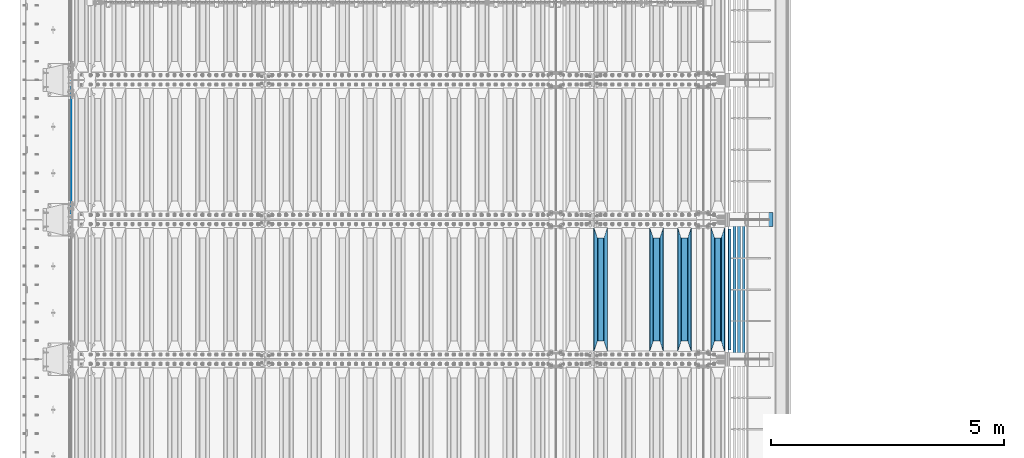
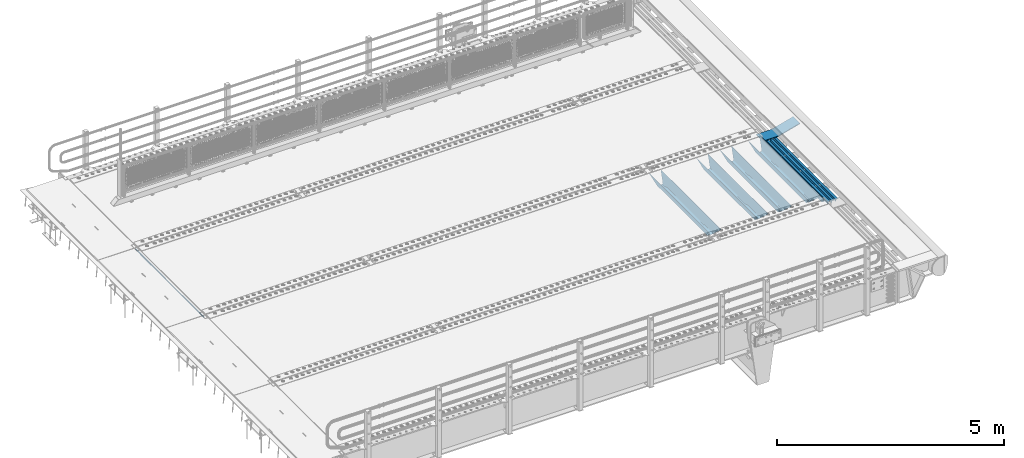
# One storey, part 111 of 240: 10 beams.
"""IFC2X3 building model written with IfcOpenShell, lengths in millimetres."""

from ifc_helpers import new_model, si_unit, frame, origin_with_axes, place, context, subcontext, project, spatial, faceted_brep, material, type_object, element, save


model = new_model("IFC2X3")

# Units and contexts
model_context = context("Model", 3, precision=1e-05, world=origin_with_axes())
body_context = subcontext(model_context, "Body", "Model", "MODEL_VIEW")
ifc_project = project(units=[si_unit("LENGTHUNIT", "METRE", prefix="MILLI"), si_unit("AREAUNIT", "SQUARE_METRE"), si_unit("VOLUMEUNIT", "CUBIC_METRE"), si_unit("MASSUNIT", "GRAM", prefix="KILO"), si_unit("TIMEUNIT", "SECOND"), si_unit("PLANEANGLEUNIT", "RADIAN"), si_unit("SOLIDANGLEUNIT", "STERADIAN"), si_unit("THERMODYNAMICTEMPERATUREUNIT", "DEGREE_CELSIUS"), si_unit("LUMINOUSINTENSITYUNIT", "LUMEN")], contexts=[model_context])

# Site, building, storey
site_placement = place(None, origin_with_axes())
site = spatial("IfcSite", under=ifc_project, at=site_placement, CompositionType="ELEMENT")
building_placement = place(site_placement, origin_with_axes())
building = spatial("IfcBuilding", under=site, at=building_placement, Name="Standard", CompositionType="ELEMENT")
storey_placement = place(building_placement, origin_with_axes())
storey = spatial("IfcBuildingStorey", under=building, at=storey_placement, Name="Undefined", CompositionType="ELEMENT", Elevation=0.0)

# Beams
ifc_material_1 = material(Name="STEEL/S355N")
beam_type_1 = type_object("IfcBeamType", Name="D20", PredefinedType="NOTDEFINED")
beam_1_placement = place(storey_placement, frame((42415.0, 30004.9999999999, -25.999999994595), z_axis=(0.0, 0.0, 1.0), x_axis=(0.0, 1.0, 0.0)))
element("IfcBeam", 1, at=beam_1_placement, inside=storey, type_object=beam_type_1, material=ifc_material_1, ObjectType="D20", context=body_context, shape_type="Brep", body=[
    faceted_brep([(0.0, -10.0, 0.0), (0.0, -7.07106781186303, -7.07106781186548), (2990.0, -7.07106781186303, -7.07106781186548), (2990.0, -10.0, 0.0), (0.0, 0.0, -10.0), (2990.0, 0.0, -10.0), (0.0, 7.07106781186303, -7.07106781186547), (2990.0, 7.07106781186303, -7.07106781186547), (0.0, 10.0, 0.0), (2990.0, 10.0, 0.0), (0.0, 7.07106781186303, 7.07106781186548), (2990.0, 7.07106781186303, 7.07106781186548), (0.0, 0.0, 10.0), (2990.0, 0.0, 10.0), (0.0, -7.07106781186303, 7.07106781186548), (2990.0, -7.07106781186303, 7.07106781186548)], [[[0, 1, 2, 3]], [[1, 4, 5, 2]], [[4, 6, 7, 5]], [[6, 8, 9, 7]], [[8, 10, 11, 9]], [[10, 12, 13, 11]], [[12, 14, 15, 13]], [[14, 0, 3, 15]], [[5, 7, 9, 11, 13, 15, 3, 2]], [[14, 12, 10, 8, 6, 4, 1, 0]]]),
])
beam_type_2 = type_object("IfcBeamType", PredefinedType="NOTDEFINED")
beam_2_placement = place(storey_placement, frame((56317.0, 27175.0, -115.0), z_axis=(0.0, 0.0, 1.0), x_axis=(0.0, 1.0, 0.0)))
element("IfcBeam", 2, at=beam_2_placement, inside=storey, type_object=beam_type_2, material=ifc_material_1, context=body_context, shape_type="Brep", body=[
    faceted_brep([(0.0, 150.0, 115.0), (0.0, 143.690000000002, 115.0), (2650.00000000297, 143.690000000002, 115.0), (2650.00000000297, 150.0, 115.0), (2650.00000000297, 142.059565218406, 110.000000003094), (2650.00000000297, 148.369565218403, 110.000000003094), (2441.90079219209, -80.1103600731149, -98.0992078077845), (2437.7588105432, -77.5672621345584, -102.241189456673), (2434.06523489747, -74.4080125315522, -105.934765102404), (2430.9108609509, -70.7102721255724, -109.089139048974), (2428.37322971128, -66.5649389910031, -111.626770288588), (2426.51472138055, -62.0739139532889, -113.485278619323), (2425.38102192092, -57.3475956567636, -114.618978078955), (2424.99999999987, -52.5021667386536, -115.0), (2424.99999999987, 52.5021667386536, -115.0), (2425.38102192092, 57.3475956567636, -114.618978078955), (2426.51472138055, 62.0739139532889, -113.485278619323), (2428.37322971128, 66.5649389910031, -111.626770288588), (2430.9108609509, 70.7102721255724, -109.089139048974), (2434.06523489747, 74.4080125315522, -105.934765102404), (2437.7588105432, 77.5672621345584, -102.241189456673), (2441.90079219209, 80.1103600731149, -98.0992078077846), (2446.38936140512, 81.9747917625791, -93.6106385947584), (2448.2494850041, 76.2713538057287, -91.7505149957729), (2444.62967112263, 74.76777986261, -95.3703288772456), (2441.28936334127, 72.7168944282894, -98.710636658607), (2438.31067330439, 70.1691124903809, -101.689326695487), (2435.76682334748, 67.1870637758839, -104.233176652398), (2433.72034654134, 63.8440531834931, -106.279653458539), (2432.22154950042, 60.2222587982324, -107.778450499454), (2431.30727574265, 56.4107117849126, -108.692724257221), (2430.99999999987, 52.5031078186876, -109.0), (2430.99999999987, -52.5031078186876, -109.0), (2431.30727574265, -56.4107117849126, -108.692724257221), (2432.22154950042, -60.2222587982324, -107.778450499454), (2433.72034654134, -63.8440531834931, -106.279653458539), (2435.76682334748, -67.1870637758839, -104.233176652398), (2438.31067330439, -70.1691124903809, -101.689326695487), (2441.28936334127, -72.7168944282894, -98.7106366586071), (2444.62967112263, -74.76777986261, -95.3703288772457), (2448.2494850041, -76.2713538057287, -91.7505149957729), (2650.00000000297, -142.059565218406, 110.000000003094), (2650.00000000297, -148.369565218403, 110.000000003094), (2446.38936140512, -81.9747917625791, -93.6106385947584), (2650.00000000297, -143.690000000002, 115.0), (2650.00000000297, -150.0, 115.0), (0.0, -143.690000000002, 115.0), (0.0, -150.0, 115.0), (0.0, -148.369565218258, 110.000000002667), (203.610638597427, -81.9747917625791, -93.6106385947584), (208.09920781045, -80.1103600731149, -98.0992078077845), (212.241189459342, -77.5672621345584, -102.241189456673), (215.93476510507, -74.4080125315522, -105.934765102404), (219.089139051641, -70.7102721255724, -109.089139048974), (221.626770291256, -66.5649389910031, -111.626770288588), (223.485278621989, -62.0739139532889, -113.485278619323), (224.618978081624, -57.3475956567636, -114.618978078955), (225.000000002663, -52.5021667386536, -115.0), (225.000000002663, 52.5021667386536, -115.0), (224.618978081624, 57.3475956567636, -114.618978078955), (223.485278621989, 62.0739139532889, -113.485278619323), (221.626770291256, 66.5649389910031, -111.626770288588), (219.089139051641, 70.7102721255724, -109.089139048974), (215.93476510507, 74.4080125315522, -105.934765102404), (212.241189459342, 77.5672621345584, -102.241189456673), (208.09920781045, 80.1103600731149, -98.0992078077846), (203.610638597427, 81.9747917625791, -93.6106385947584), (0.0, 148.369565218258, 110.000000002667), (0.0, 142.05956521826, 110.000000002667), (201.750514998439, 76.2713538057287, -91.7505149957729), (205.370328879908, 74.76777986261, -95.3703288772456), (208.710636661275, 72.7168944282894, -98.710636658607), (211.689326698153, 70.1691124903809, -101.689326695487), (214.233176655063, 67.1870637758839, -104.233176652398), (216.279653461206, 63.8440531834931, -106.279653458539), (217.778450502123, 60.2222587982324, -107.778450499454), (218.692724259887, 56.4107117849126, -108.692724257221), (219.000000002667, 52.5031078186876, -109.0), (219.000000002667, -52.5031078186876, -109.0), (218.692724259887, -56.4107117849126, -108.692724257221), (217.778450502123, -60.2222587982324, -107.778450499454), (216.279653461206, -63.8440531834931, -106.279653458539), (214.233176655063, -67.1870637758839, -104.233176652398), (211.689326698153, -70.1691124903809, -101.689326695487), (208.710636661275, -72.7168944282894, -98.7106366586071), (205.370328879915, -74.76777986261, -95.3703288772457), (201.750514998439, -76.2713538057287, -91.7505149957729), (0.0, -142.05956521826, 110.000000002667)], [[[0, 1, 2, 3]], [[3, 2, 4, 5]], [[6, 7, 8, 9, 10, 11, 12, 13, 14, 15, 16, 17, 18, 19, 20, 21, 22, 5, 4, 23, 24, 25, 26, 27, 28, 29, 30, 31, 32, 33, 34, 35, 36, 37, 38, 39, 40, 41, 42, 43]], [[44, 45, 42, 41]], [[46, 47, 45, 44]], [[43, 42, 45, 47, 48, 49]], [[6, 43, 49, 50]], [[7, 6, 50, 51]], [[8, 7, 51, 52]], [[9, 8, 52, 53]], [[10, 9, 53, 54]], [[11, 10, 54, 55]], [[12, 11, 55, 56]], [[13, 12, 56, 57]], [[14, 13, 57, 58]], [[15, 14, 58, 59]], [[16, 15, 59, 60]], [[17, 16, 60, 61]], [[18, 17, 61, 62]], [[19, 18, 62, 63]], [[20, 19, 63, 64]], [[21, 20, 64, 65]], [[22, 21, 65, 66]], [[0, 3, 5, 22, 66, 67]], [[1, 0, 67, 68]], [[23, 4, 2, 1, 68, 69]], [[24, 23, 69, 70]], [[25, 24, 70, 71]], [[26, 25, 71, 72]], [[27, 26, 72, 73]], [[28, 27, 73, 74]], [[29, 28, 74, 75]], [[30, 29, 75, 76]], [[31, 30, 76, 77]], [[32, 31, 77, 78]], [[33, 32, 78, 79]], [[34, 33, 79, 80]], [[35, 34, 80, 81]], [[36, 35, 81, 82]], [[37, 36, 82, 83]], [[38, 37, 83, 84]], [[39, 38, 84, 85]], [[40, 39, 85, 86]], [[46, 44, 41, 40, 86, 87]], [[47, 46, 87, 48]], [[86, 85, 84, 83, 82, 81, 80, 79, 78, 77, 76, 75, 74, 73, 72, 71, 70, 69, 68, 67, 66, 65, 64, 63, 62, 61, 60, 59, 58, 57, 56, 55, 54, 53, 52, 51, 50, 49, 48, 87]]]),
])
beam_3_placement = place(storey_placement, frame((55600.0, 27175.0, -115.0), z_axis=(0.0, 0.0, 1.0), x_axis=(0.0, 1.0, 0.0)))
element("IfcBeam", 3, at=beam_3_placement, inside=storey, type_object=beam_type_2, material=ifc_material_1, context=body_context, shape_type="Brep", body=[
    faceted_brep([(0.0, 150.0, 115.0), (0.0, 143.690000000002, 115.0), (2650.00000000297, 143.690000000002, 115.0), (2650.00000000297, 150.0, 115.0), (2650.00000000297, 142.059565218406, 110.000000003094), (2650.00000000297, 148.369565218403, 110.000000003094), (2441.90079219209, -80.1103600731149, -98.0992078077845), (2437.7588105432, -77.5672621345584, -102.241189456673), (2434.06523489747, -74.4080125315522, -105.934765102404), (2430.9108609509, -70.7102721255724, -109.089139048974), (2428.37322971128, -66.5649389910031, -111.626770288588), (2426.51472138055, -62.0739139532889, -113.485278619323), (2425.38102192092, -57.3475956567636, -114.618978078955), (2424.99999999987, -52.5021667386536, -115.0), (2424.99999999987, 52.5021667386536, -115.0), (2425.38102192092, 57.3475956567636, -114.618978078955), (2426.51472138055, 62.0739139532889, -113.485278619323), (2428.37322971128, 66.5649389910031, -111.626770288588), (2430.9108609509, 70.7102721255724, -109.089139048974), (2434.06523489747, 74.4080125315522, -105.934765102404), (2437.7588105432, 77.5672621345584, -102.241189456673), (2441.90079219209, 80.1103600731149, -98.0992078077846), (2446.38936140512, 81.9747917625791, -93.6106385947584), (2448.2494850041, 76.2713538057287, -91.7505149957729), (2444.62967112263, 74.76777986261, -95.3703288772456), (2441.28936334127, 72.7168944282894, -98.710636658607), (2438.31067330439, 70.1691124903809, -101.689326695487), (2435.76682334748, 67.1870637758839, -104.233176652398), (2433.72034654134, 63.8440531834931, -106.279653458539), (2432.22154950042, 60.2222587982324, -107.778450499454), (2431.30727574265, 56.4107117849126, -108.692724257221), (2430.99999999987, 52.5031078186876, -109.0), (2430.99999999987, -52.5031078186876, -109.0), (2431.30727574265, -56.4107117849126, -108.692724257221), (2432.22154950042, -60.2222587982324, -107.778450499454), (2433.72034654134, -63.8440531834931, -106.279653458539), (2435.76682334748, -67.1870637758839, -104.233176652398), (2438.31067330439, -70.1691124903809, -101.689326695487), (2441.28936334127, -72.7168944282894, -98.7106366586071), (2444.62967112263, -74.76777986261, -95.3703288772457), (2448.2494850041, -76.2713538057287, -91.7505149957729), (2650.00000000297, -142.059565218406, 110.000000003094), (2650.00000000297, -148.369565218403, 110.000000003094), (2446.38936140512, -81.9747917625791, -93.6106385947584), (2650.00000000297, -143.690000000002, 115.0), (2650.00000000297, -150.0, 115.0), (0.0, -143.690000000002, 115.0), (0.0, -150.0, 115.0), (0.0, -148.369565218258, 110.000000002667), (203.610638597427, -81.9747917625791, -93.6106385947584), (208.09920781045, -80.1103600731149, -98.0992078077845), (212.241189459342, -77.5672621345584, -102.241189456673), (215.93476510507, -74.4080125315522, -105.934765102404), (219.089139051641, -70.7102721255724, -109.089139048974), (221.626770291256, -66.5649389910031, -111.626770288588), (223.485278621989, -62.0739139532889, -113.485278619323), (224.618978081624, -57.3475956567636, -114.618978078955), (225.000000002663, -52.5021667386536, -115.0), (225.000000002663, 52.5021667386536, -115.0), (224.618978081624, 57.3475956567636, -114.618978078955), (223.485278621989, 62.0739139532889, -113.485278619323), (221.626770291256, 66.5649389910031, -111.626770288588), (219.089139051641, 70.7102721255724, -109.089139048974), (215.93476510507, 74.4080125315522, -105.934765102404), (212.241189459342, 77.5672621345584, -102.241189456673), (208.09920781045, 80.1103600731149, -98.0992078077846), (203.610638597427, 81.9747917625791, -93.6106385947584), (0.0, 148.369565218258, 110.000000002667), (0.0, 142.05956521826, 110.000000002667), (201.750514998439, 76.2713538057287, -91.7505149957729), (205.370328879908, 74.76777986261, -95.3703288772456), (208.710636661275, 72.7168944282894, -98.710636658607), (211.689326698153, 70.1691124903809, -101.689326695487), (214.233176655063, 67.1870637758839, -104.233176652398), (216.279653461206, 63.8440531834931, -106.279653458539), (217.778450502123, 60.2222587982324, -107.778450499454), (218.692724259887, 56.4107117849126, -108.692724257221), (219.000000002667, 52.5031078186876, -109.0), (219.000000002667, -52.5031078186876, -109.0), (218.692724259887, -56.4107117849126, -108.692724257221), (217.778450502123, -60.2222587982324, -107.778450499454), (216.279653461206, -63.8440531834931, -106.279653458539), (214.233176655063, -67.1870637758839, -104.233176652398), (211.689326698153, -70.1691124903809, -101.689326695487), (208.710636661275, -72.7168944282894, -98.7106366586071), (205.370328879915, -74.76777986261, -95.3703288772457), (201.750514998439, -76.2713538057287, -91.7505149957729), (0.0, -142.05956521826, 110.000000002667)], [[[0, 1, 2, 3]], [[3, 2, 4, 5]], [[6, 7, 8, 9, 10, 11, 12, 13, 14, 15, 16, 17, 18, 19, 20, 21, 22, 5, 4, 23, 24, 25, 26, 27, 28, 29, 30, 31, 32, 33, 34, 35, 36, 37, 38, 39, 40, 41, 42, 43]], [[44, 45, 42, 41]], [[46, 47, 45, 44]], [[43, 42, 45, 47, 48, 49]], [[6, 43, 49, 50]], [[7, 6, 50, 51]], [[8, 7, 51, 52]], [[9, 8, 52, 53]], [[10, 9, 53, 54]], [[11, 10, 54, 55]], [[12, 11, 55, 56]], [[13, 12, 56, 57]], [[14, 13, 57, 58]], [[15, 14, 58, 59]], [[16, 15, 59, 60]], [[17, 16, 60, 61]], [[18, 17, 61, 62]], [[19, 18, 62, 63]], [[20, 19, 63, 64]], [[21, 20, 64, 65]], [[22, 21, 65, 66]], [[0, 3, 5, 22, 66, 67]], [[1, 0, 67, 68]], [[23, 4, 2, 1, 68, 69]], [[24, 23, 69, 70]], [[25, 24, 70, 71]], [[26, 25, 71, 72]], [[27, 26, 72, 73]], [[28, 27, 73, 74]], [[29, 28, 74, 75]], [[30, 29, 75, 76]], [[31, 30, 76, 77]], [[32, 31, 77, 78]], [[33, 32, 78, 79]], [[34, 33, 79, 80]], [[35, 34, 80, 81]], [[36, 35, 81, 82]], [[37, 36, 82, 83]], [[38, 37, 83, 84]], [[39, 38, 84, 85]], [[40, 39, 85, 86]], [[46, 44, 41, 40, 86, 87]], [[47, 46, 87, 48]], [[86, 85, 84, 83, 82, 81, 80, 79, 78, 77, 76, 75, 74, 73, 72, 71, 70, 69, 68, 67, 66, 65, 64, 63, 62, 61, 60, 59, 58, 57, 56, 55, 54, 53, 52, 51, 50, 49, 48, 87]]]),
])
beam_4_placement = place(storey_placement, frame((55000.0, 27175.0, -115.0), z_axis=(0.0, 0.0, 1.0), x_axis=(0.0, 1.0, 0.0)))
element("IfcBeam", 4, at=beam_4_placement, inside=storey, type_object=beam_type_2, material=ifc_material_1, context=body_context, shape_type="Brep", body=[
    faceted_brep([(0.0, 150.0, 115.0), (0.0, 143.690000000002, 115.0), (2650.00000000297, 143.690000000002, 115.0), (2650.00000000297, 150.0, 115.0), (2650.00000000297, 142.059565218406, 110.000000003094), (2650.00000000297, 148.369565218403, 110.000000003094), (2441.90079219209, -80.1103600731149, -98.0992078077845), (2437.7588105432, -77.5672621345584, -102.241189456673), (2434.06523489747, -74.4080125315522, -105.934765102404), (2430.9108609509, -70.7102721255724, -109.089139048974), (2428.37322971128, -66.5649389910031, -111.626770288588), (2426.51472138055, -62.0739139532889, -113.485278619323), (2425.38102192092, -57.3475956567636, -114.618978078955), (2424.99999999987, -52.5021667386536, -115.0), (2424.99999999987, 52.5021667386536, -115.0), (2425.38102192092, 57.3475956567636, -114.618978078955), (2426.51472138055, 62.0739139532889, -113.485278619323), (2428.37322971128, 66.5649389910031, -111.626770288588), (2430.9108609509, 70.7102721255724, -109.089139048974), (2434.06523489747, 74.4080125315522, -105.934765102404), (2437.7588105432, 77.5672621345584, -102.241189456673), (2441.90079219209, 80.1103600731149, -98.0992078077846), (2446.38936140512, 81.9747917625791, -93.6106385947584), (2448.2494850041, 76.2713538057287, -91.7505149957729), (2444.62967112263, 74.76777986261, -95.3703288772456), (2441.28936334127, 72.7168944282894, -98.710636658607), (2438.31067330439, 70.1691124903809, -101.689326695487), (2435.76682334748, 67.1870637758839, -104.233176652398), (2433.72034654134, 63.8440531834931, -106.279653458539), (2432.22154950042, 60.2222587982324, -107.778450499454), (2431.30727574265, 56.4107117849126, -108.692724257221), (2430.99999999987, 52.5031078186876, -109.0), (2430.99999999987, -52.5031078186876, -109.0), (2431.30727574265, -56.4107117849126, -108.692724257221), (2432.22154950042, -60.2222587982324, -107.778450499454), (2433.72034654134, -63.8440531834931, -106.279653458539), (2435.76682334748, -67.1870637758839, -104.233176652398), (2438.31067330439, -70.1691124903809, -101.689326695487), (2441.28936334127, -72.7168944282894, -98.7106366586071), (2444.62967112263, -74.76777986261, -95.3703288772457), (2448.2494850041, -76.2713538057287, -91.7505149957729), (2650.00000000297, -142.059565218406, 110.000000003094), (2650.00000000297, -148.369565218403, 110.000000003094), (2446.38936140512, -81.9747917625791, -93.6106385947584), (2650.00000000297, -143.690000000002, 115.0), (2650.00000000297, -150.0, 115.0), (0.0, -143.690000000002, 115.0), (0.0, -150.0, 115.0), (0.0, -148.369565218258, 110.000000002667), (203.610638597427, -81.9747917625791, -93.6106385947584), (208.09920781045, -80.1103600731149, -98.0992078077845), (212.241189459342, -77.5672621345584, -102.241189456673), (215.93476510507, -74.4080125315522, -105.934765102404), (219.089139051641, -70.7102721255724, -109.089139048974), (221.626770291256, -66.5649389910031, -111.626770288588), (223.485278621989, -62.0739139532889, -113.485278619323), (224.618978081624, -57.3475956567636, -114.618978078955), (225.000000002663, -52.5021667386536, -115.0), (225.000000002663, 52.5021667386536, -115.0), (224.618978081624, 57.3475956567636, -114.618978078955), (223.485278621989, 62.0739139532889, -113.485278619323), (221.626770291256, 66.5649389910031, -111.626770288588), (219.089139051641, 70.7102721255724, -109.089139048974), (215.93476510507, 74.4080125315522, -105.934765102404), (212.241189459342, 77.5672621345584, -102.241189456673), (208.09920781045, 80.1103600731149, -98.0992078077846), (203.610638597427, 81.9747917625791, -93.6106385947584), (0.0, 148.369565218258, 110.000000002667), (0.0, 142.05956521826, 110.000000002667), (201.750514998439, 76.2713538057287, -91.7505149957729), (205.370328879908, 74.76777986261, -95.3703288772456), (208.710636661275, 72.7168944282894, -98.710636658607), (211.689326698153, 70.1691124903809, -101.689326695487), (214.233176655063, 67.1870637758839, -104.233176652398), (216.279653461206, 63.8440531834931, -106.279653458539), (217.778450502123, 60.2222587982324, -107.778450499454), (218.692724259887, 56.4107117849126, -108.692724257221), (219.000000002667, 52.5031078186876, -109.0), (219.000000002667, -52.5031078186876, -109.0), (218.692724259887, -56.4107117849126, -108.692724257221), (217.778450502123, -60.2222587982324, -107.778450499454), (216.279653461206, -63.8440531834931, -106.279653458539), (214.233176655063, -67.1870637758839, -104.233176652398), (211.689326698153, -70.1691124903809, -101.689326695487), (208.710636661275, -72.7168944282894, -98.7106366586071), (205.370328879915, -74.76777986261, -95.3703288772457), (201.750514998439, -76.2713538057287, -91.7505149957729), (0.0, -142.05956521826, 110.000000002667)], [[[0, 1, 2, 3]], [[3, 2, 4, 5]], [[6, 7, 8, 9, 10, 11, 12, 13, 14, 15, 16, 17, 18, 19, 20, 21, 22, 5, 4, 23, 24, 25, 26, 27, 28, 29, 30, 31, 32, 33, 34, 35, 36, 37, 38, 39, 40, 41, 42, 43]], [[44, 45, 42, 41]], [[46, 47, 45, 44]], [[43, 42, 45, 47, 48, 49]], [[6, 43, 49, 50]], [[7, 6, 50, 51]], [[8, 7, 51, 52]], [[9, 8, 52, 53]], [[10, 9, 53, 54]], [[11, 10, 54, 55]], [[12, 11, 55, 56]], [[13, 12, 56, 57]], [[14, 13, 57, 58]], [[15, 14, 58, 59]], [[16, 15, 59, 60]], [[17, 16, 60, 61]], [[18, 17, 61, 62]], [[19, 18, 62, 63]], [[20, 19, 63, 64]], [[21, 20, 64, 65]], [[22, 21, 65, 66]], [[0, 3, 5, 22, 66, 67]], [[1, 0, 67, 68]], [[23, 4, 2, 1, 68, 69]], [[24, 23, 69, 70]], [[25, 24, 70, 71]], [[26, 25, 71, 72]], [[27, 26, 72, 73]], [[28, 27, 73, 74]], [[29, 28, 74, 75]], [[30, 29, 75, 76]], [[31, 30, 76, 77]], [[32, 31, 77, 78]], [[33, 32, 78, 79]], [[34, 33, 79, 80]], [[35, 34, 80, 81]], [[36, 35, 81, 82]], [[37, 36, 82, 83]], [[38, 37, 83, 84]], [[39, 38, 84, 85]], [[40, 39, 85, 86]], [[46, 44, 41, 40, 86, 87]], [[47, 46, 87, 48]], [[86, 85, 84, 83, 82, 81, 80, 79, 78, 77, 76, 75, 74, 73, 72, 71, 70, 69, 68, 67, 66, 65, 64, 63, 62, 61, 60, 59, 58, 57, 56, 55, 54, 53, 52, 51, 50, 49, 48, 87]]]),
])
beam_5_placement = place(storey_placement, frame((53800.0, 27175.0, -115.0), z_axis=(0.0, 0.0, 1.0), x_axis=(0.0, 1.0, 0.0)))
element("IfcBeam", 5, at=beam_5_placement, inside=storey, type_object=beam_type_2, material=ifc_material_1, context=body_context, shape_type="Brep", body=[
    faceted_brep([(0.0, 150.0, 115.0), (0.0, 143.690000000002, 115.0), (2650.00000000297, 143.690000000002, 115.0), (2650.00000000297, 150.0, 115.0), (2650.00000000297, 142.059565218406, 110.000000003094), (2650.00000000297, 148.369565218403, 110.000000003094), (2441.90079219209, -80.1103600731149, -98.0992078077845), (2437.7588105432, -77.5672621345584, -102.241189456673), (2434.06523489747, -74.4080125315522, -105.934765102404), (2430.9108609509, -70.7102721255724, -109.089139048974), (2428.37322971128, -66.5649389910031, -111.626770288588), (2426.51472138055, -62.0739139532889, -113.485278619323), (2425.38102192092, -57.3475956567636, -114.618978078955), (2424.99999999987, -52.5021667386536, -115.0), (2424.99999999987, 52.5021667386536, -115.0), (2425.38102192092, 57.3475956567636, -114.618978078955), (2426.51472138055, 62.0739139532889, -113.485278619323), (2428.37322971128, 66.5649389910031, -111.626770288588), (2430.9108609509, 70.7102721255724, -109.089139048974), (2434.06523489747, 74.4080125315522, -105.934765102404), (2437.7588105432, 77.5672621345584, -102.241189456673), (2441.90079219209, 80.1103600731149, -98.0992078077846), (2446.38936140512, 81.9747917625791, -93.6106385947584), (2448.2494850041, 76.2713538057287, -91.7505149957729), (2444.62967112263, 74.76777986261, -95.3703288772456), (2441.28936334127, 72.7168944282894, -98.710636658607), (2438.31067330439, 70.1691124903809, -101.689326695487), (2435.76682334748, 67.1870637758839, -104.233176652398), (2433.72034654134, 63.8440531834931, -106.279653458539), (2432.22154950042, 60.2222587982324, -107.778450499454), (2431.30727574265, 56.4107117849126, -108.692724257221), (2430.99999999987, 52.5031078186876, -109.0), (2430.99999999987, -52.5031078186876, -109.0), (2431.30727574265, -56.4107117849126, -108.692724257221), (2432.22154950042, -60.2222587982324, -107.778450499454), (2433.72034654134, -63.8440531834931, -106.279653458539), (2435.76682334748, -67.1870637758839, -104.233176652398), (2438.31067330439, -70.1691124903809, -101.689326695487), (2441.28936334127, -72.7168944282894, -98.7106366586071), (2444.62967112263, -74.76777986261, -95.3703288772457), (2448.2494850041, -76.2713538057287, -91.7505149957729), (2650.00000000297, -142.059565218406, 110.000000003094), (2650.00000000297, -148.369565218403, 110.000000003094), (2446.38936140512, -81.9747917625791, -93.6106385947584), (2650.00000000297, -143.690000000002, 115.0), (2650.00000000297, -150.0, 115.0), (0.0, -143.690000000002, 115.0), (0.0, -150.0, 115.0), (0.0, -148.369565218258, 110.000000002667), (203.610638597427, -81.9747917625791, -93.6106385947584), (208.09920781045, -80.1103600731149, -98.0992078077845), (212.241189459342, -77.5672621345584, -102.241189456673), (215.93476510507, -74.4080125315522, -105.934765102404), (219.089139051641, -70.7102721255724, -109.089139048974), (221.626770291256, -66.5649389910031, -111.626770288588), (223.485278621989, -62.0739139532889, -113.485278619323), (224.618978081624, -57.3475956567636, -114.618978078955), (225.000000002663, -52.5021667386536, -115.0), (225.000000002663, 52.5021667386536, -115.0), (224.618978081624, 57.3475956567636, -114.618978078955), (223.485278621989, 62.0739139532889, -113.485278619323), (221.626770291256, 66.5649389910031, -111.626770288588), (219.089139051641, 70.7102721255724, -109.089139048974), (215.93476510507, 74.4080125315522, -105.934765102404), (212.241189459342, 77.5672621345584, -102.241189456673), (208.09920781045, 80.1103600731149, -98.0992078077846), (203.610638597427, 81.9747917625791, -93.6106385947584), (0.0, 148.369565218258, 110.000000002667), (0.0, 142.05956521826, 110.000000002667), (201.750514998439, 76.2713538057287, -91.7505149957729), (205.370328879908, 74.76777986261, -95.3703288772456), (208.710636661275, 72.7168944282894, -98.710636658607), (211.689326698153, 70.1691124903809, -101.689326695487), (214.233176655063, 67.1870637758839, -104.233176652398), (216.279653461206, 63.8440531834931, -106.279653458539), (217.778450502123, 60.2222587982324, -107.778450499454), (218.692724259887, 56.4107117849126, -108.692724257221), (219.000000002667, 52.5031078186876, -109.0), (219.000000002667, -52.5031078186876, -109.0), (218.692724259887, -56.4107117849126, -108.692724257221), (217.778450502123, -60.2222587982324, -107.778450499454), (216.279653461206, -63.8440531834931, -106.279653458539), (214.233176655063, -67.1870637758839, -104.233176652398), (211.689326698153, -70.1691124903809, -101.689326695487), (208.710636661275, -72.7168944282894, -98.7106366586071), (205.370328879915, -74.76777986261, -95.3703288772457), (201.750514998439, -76.2713538057287, -91.7505149957729), (0.0, -142.05956521826, 110.000000002667)], [[[0, 1, 2, 3]], [[3, 2, 4, 5]], [[6, 7, 8, 9, 10, 11, 12, 13, 14, 15, 16, 17, 18, 19, 20, 21, 22, 5, 4, 23, 24, 25, 26, 27, 28, 29, 30, 31, 32, 33, 34, 35, 36, 37, 38, 39, 40, 41, 42, 43]], [[44, 45, 42, 41]], [[46, 47, 45, 44]], [[43, 42, 45, 47, 48, 49]], [[6, 43, 49, 50]], [[7, 6, 50, 51]], [[8, 7, 51, 52]], [[9, 8, 52, 53]], [[10, 9, 53, 54]], [[11, 10, 54, 55]], [[12, 11, 55, 56]], [[13, 12, 56, 57]], [[14, 13, 57, 58]], [[15, 14, 58, 59]], [[16, 15, 59, 60]], [[17, 16, 60, 61]], [[18, 17, 61, 62]], [[19, 18, 62, 63]], [[20, 19, 63, 64]], [[21, 20, 64, 65]], [[22, 21, 65, 66]], [[0, 3, 5, 22, 66, 67]], [[1, 0, 67, 68]], [[23, 4, 2, 1, 68, 69]], [[24, 23, 69, 70]], [[25, 24, 70, 71]], [[26, 25, 71, 72]], [[27, 26, 72, 73]], [[28, 27, 73, 74]], [[29, 28, 74, 75]], [[30, 29, 75, 76]], [[31, 30, 76, 77]], [[32, 31, 77, 78]], [[33, 32, 78, 79]], [[34, 33, 79, 80]], [[35, 34, 80, 81]], [[36, 35, 81, 82]], [[37, 36, 82, 83]], [[38, 37, 83, 84]], [[39, 38, 84, 85]], [[40, 39, 85, 86]], [[46, 44, 41, 40, 86, 87]], [[47, 46, 87, 48]], [[86, 85, 84, 83, 82, 81, 80, 79, 78, 77, 76, 75, 74, 73, 72, 71, 70, 69, 68, 67, 66, 65, 64, 63, 62, 61, 60, 59, 58, 57, 56, 55, 54, 53, 52, 51, 50, 49, 48, 87]]]),
])
ifc_material_2 = material(Name="STEEL/S355J2")
beam_type_3 = type_object("IfcBeamType", PredefinedType="NOTDEFINED")
beam_6_placement = place(storey_placement, frame((56564.5025260065, 27150.0, -124.999999999977), z_axis=(0.0, 0.0, 1.0), x_axis=(0.0, 1.0, 0.0)))
element("IfcBeam", 6, at=beam_6_placement, inside=storey, type_object=beam_type_3, material=ifc_material_2, context=body_context, shape_type="Brep", body=[
    faceted_brep([(2700.0, 22.5, -15.0), (2684.54915028125, 22.5, -17.4471741852423), (2684.54915028125, 32.4999999999927, -17.4471741852423), (2700.0, 32.5, -15.0), (2670.61073738538, 22.5, -24.5491502812526), (2670.61073738538, 32.4999999999927, -24.5491502812526), (2659.54915028125, 22.5, -35.6107373853764), (2659.54915028125, 32.4999999999927, -35.6107373853764), (2652.44717418524, 22.5, -49.5491502812526), (2652.44717418524, 32.4999999999927, -49.5491502812526), (2651.58384440325, -32.5, -55.0), (2650.0, -32.5, -65.0), (2650.0, 32.5, -65.0), (2651.58384440325, 22.5, -55.0), (0.0, 32.5, 65.0), (0.0, 22.5, 65.0), (2700.0, 22.5, 65.0), (2700.0, 32.5, 65.0), (0.0, 32.5, -15.0), (0.0, 22.5, -15.0), (15.4508497187489, 32.5, -17.4471741852423), (15.4508497187489, 22.5, -17.4471741852423), (29.3892626146226, 32.5, -24.5491502812526), (29.3892626146226, 22.5, -24.5491502812526), (40.4508497187489, 32.5, -35.6107373853763), (40.4508497187489, 22.5, -35.6107373853763), (47.5528258147569, 32.5, -49.5491502812526), (47.5528258147569, 22.5, -49.5491502812526), (50.0, -32.5, -65.0), (48.4161555967512, -32.5, -55.0), (48.4161555967512, 22.5, -55.0), (50.0, 32.5, -65.0)], [[[0, 1, 2, 3]], [[4, 5, 2, 1]], [[6, 7, 5, 4]], [[8, 9, 7, 6]], [[10, 11, 12, 9, 8, 13]], [[14, 15, 16, 17]], [[15, 14, 18, 19]], [[19, 18, 20, 21]], [[21, 20, 22, 23]], [[23, 22, 24, 25]], [[25, 24, 26, 27]], [[28, 29, 30, 27, 26, 31]], [[30, 29, 10, 13]], [[16, 15, 19, 21, 23, 25, 27, 30, 13, 8, 6, 4, 1, 0]], [[17, 16, 0, 3]], [[5, 7, 9, 12, 31, 26, 24, 22, 20, 18, 14, 17, 3, 2]], [[28, 31, 12, 11]], [[29, 28, 11, 10]]]),
])
beam_type_4 = type_object("IfcBeamType", PredefinedType="NOTDEFINED")
beam_7_placement = place(storey_placement, frame((56556.9988298907, 30000.0, -169.999999999995), z_axis=(0.0, -1.0, 0.0), x_axis=(1.0, 0.0, 0.0)))
element("IfcBeam", 7, at=beam_7_placement, inside=storey, type_object=beam_type_4, material=ifc_material_1, context=body_context, shape_type="Brep", body=[
    faceted_brep([(0.0, 10.0, -150.0), (0.0, 10.0, 150.0), (356.495387467709, 10.0, 150.0), (356.495387467716, 10.0000000000045, -150.0), (0.0, -10.0, 150.0), (0.0, -10.0, -150.0), (356.495387467709, -10.0, -150.0), (356.495387467709, -10.0, 150.0), (382.770279632619, 11.7334369042659, 150.0), (382.770279632619, 11.7334369042659, -150.0), (385.397768849085, -8.09321940530759, -150.0), (385.397768849085, -8.09321940530759, 150.0), (413.799145685371, -2.40593045938311, -150.0), (413.799145685371, -2.40593045938311, 150.0), (408.589713120156, 16.903699582373, 150.0), (408.589713119858, 16.9036995827009, -150.0), (938.999999999978, 160.0, 150.0), (938.999999999978, 160.0, -150.0), (944.209432565192, 140.69036995827, 150.0), (944.209432565192, 140.69036995827, -150.0)], [[[0, 1, 2, 3]], [[4, 5, 6, 7]], [[5, 4, 1, 0]], [[3, 2, 8, 9]], [[7, 6, 10, 11]], [[10, 12, 13, 11]], [[8, 14, 15, 9]], [[15, 14, 16, 17]], [[14, 8, 2, 1, 4, 7, 11, 13, 18, 16]], [[13, 12, 19, 18]], [[12, 10, 6, 5, 0, 3, 9, 15, 17, 19]], [[18, 19, 17, 16]]]),
])
beam_type_5 = type_object("IfcBeamType", PredefinedType="NOTDEFINED")
for number, where, z_axis, x_axis in (
    (8, (56872.0025260169, 29869.9999003886, -209.999999999563), (0.0, 0.0, -1.0), (0.0, -1.0, 0.0)),
    (9, (56772.0025260169, 29869.9999003886, -209.999999999563), (0.0, 0.0, -1.0), (0.0, -1.0, 0.0)),
    (10, (56672.0025260162, 29870.0000023132, -209.999999999622), (0.0, 0.0, -1.0), (0.0, -1.0, 0.0)),
):
    element("IfcBeam", number, at=place(storey_placement, frame(where, z_axis=z_axis, x_axis=x_axis)), inside=storey, type_object=beam_type_5, material=ifc_material_2, context=body_context, shape_type="Brep", body=[
        faceted_brep([(-3.63797880709171e-12, 29.9999999999927, -29.9999999999999), (-3.63797880709171e-12, 29.9999999999927, 30.0000000000001), (2740.00017042501, 29.9999999999927, 30.0000000000001), (2740.00017042501, 29.9999999999927, -29.9999999999999), (-3.63797880709171e-12, 23.9999999999927, 30.0), (2740.00017042501, 23.9999999999927, 30.0), (-3.63797880709171e-12, 23.9999999999927, -24.0), (2740.00017042501, 23.9999999999927, -24.0), (-7.27595761418343e-12, -30.0000000000073, -24.0), (2740.00017042501, -30.0000000000073, -24.0), (-3.63797880709171e-12, -30.0000000000073, -30.0), (2740.00017042501, -30.0000000000073, -30.0)], [[[0, 1, 2, 3]], [[1, 4, 5, 2]], [[4, 6, 7, 5]], [[6, 8, 9, 7]], [[8, 10, 11, 9]], [[10, 0, 3, 11]], [[5, 7, 9, 11, 3, 2]], [[10, 8, 6, 4, 1, 0]]]),
    ])

save(model, "model.ifc")
